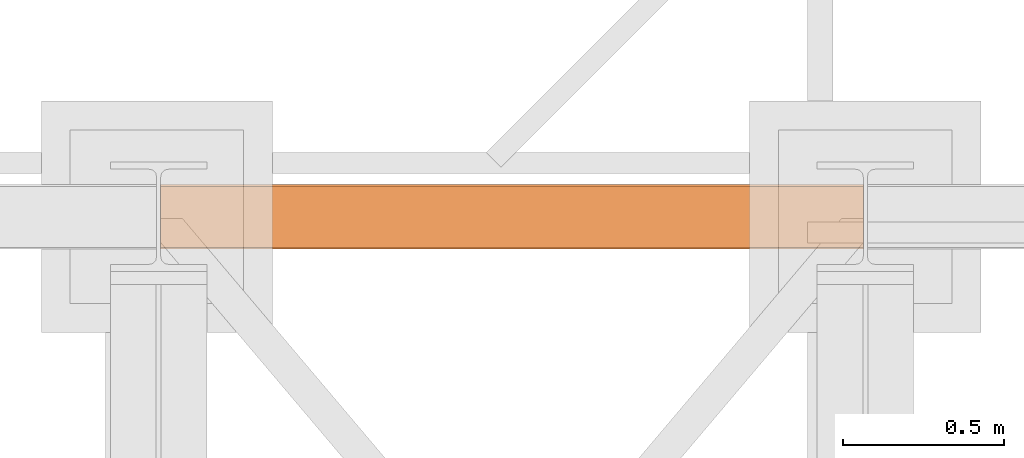
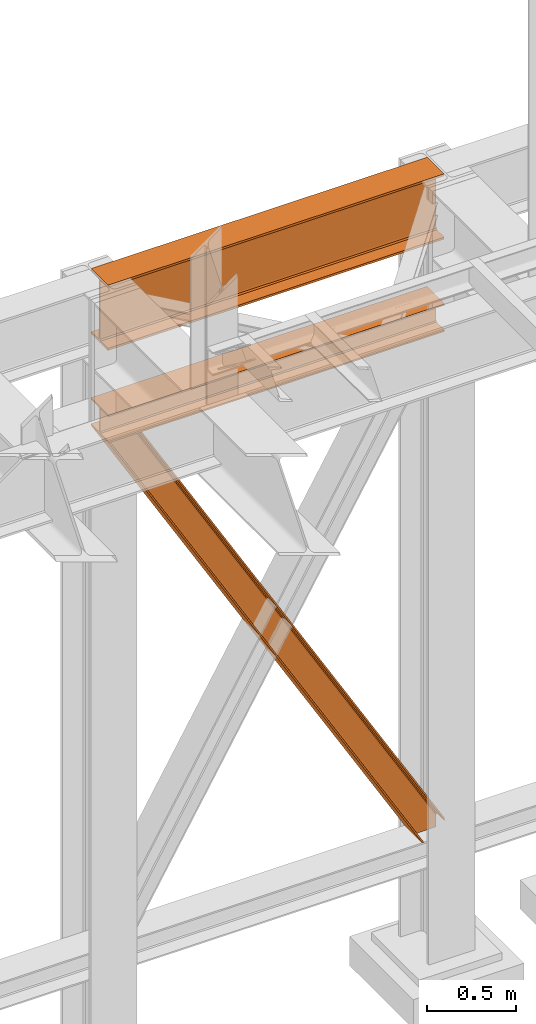
# One storey, part 191 of 208: 3 proxies.
"""IFC2X3 building model written with IfcOpenShell, lengths in millimetres."""

from ifc_helpers import new_model, entity, si_unit, converted_unit, frame, origin, origin_with_axes, place, context, subcontext, project, spatial, faceted_brep, element, save


model = new_model("IFC2X3")

# Units and contexts
model_context = context("Model", 3, precision=1e-05, world=origin())
plan_context = context("Plan", 3, precision=1e-05, world=origin())
body_context = subcontext(model_context, "Body", "Model", "MODEL_VIEW")
ifc_project = project(units=[si_unit("LENGTHUNIT", "METRE", prefix="MILLI"), converted_unit("PLANEANGLEUNIT", "DEGREE", entity("IfcPlaneAngleMeasure", 0.0174532925199433), si_unit("PLANEANGLEUNIT", "RADIAN"), dimensions=[0, 0, 0, 0, 0, 0, 0]), si_unit("AREAUNIT", "SQUARE_METRE"), si_unit("VOLUMEUNIT", "CUBIC_METRE")], contexts=[model_context, plan_context])

# Building, storey
building_placement = place(None, origin())
building = spatial("IfcBuilding", under=ifc_project, at=building_placement, CompositionType="COMPLEX")
storey_placement = place(building_placement, origin_with_axes())
storey = spatial("IfcBuildingStorey", under=building, at=storey_placement, Name="Geschoss", CompositionType="ELEMENT")

# Proxies
proxy_1_placement = place(storey_placement, frame((3299.254968580828, -12557.574399786, 4834.989987483023), z_axis=(0.0, 0.0, 1.0), x_axis=(1.0, 0.0, 0.0)))
element("IfcBuildingElementProxy", 1, at=proxy_1_placement, inside=storey, context=body_context, shape_type="Brep", body=[
    faceted_brep([(2188.009999895692, 0.00999999999839929, 450.0100178813937), (2188.009999895692, 190.0100125169738, 450.0100178813937), (2188.009999895692, 190.0100125169738, 435.4100240564349), (2188.009999895692, 120.7100073045476, 435.4100091552737), (2188.009999895692, 109.8415622657522, 433.2347078418734), (2188.009999895692, 101.8853126263603, 425.2784563398363), (2188.009999895692, 99.71000619068582, 414.4100113010409), (2188.009999895692, 99.71000619068582, 35.60999167919181), (2188.009999895692, 101.8853126263603, 24.74154664039634), (2188.009999895692, 109.8415622657522, 16.78529513835929), (2188.009999895692, 120.7100073045476, 14.60999382495902), (2188.009999895692, 190.0100125169738, 14.60999382495902), (2188.009999895692, 190.0100125169738, 0.01000000000021828), (2188.009999895692, 0.00999999999839929, 0.01000000000021828), (2188.009999895692, 0.00999999999839929, 14.60999382495902), (2188.009999895692, 69.31000521242458, 14.60999382495902), (2188.009999895692, 80.17845025122006, 16.78529513835929), (2188.009999895692, 88.13469989061196, 24.74154664039634), (2188.009999895692, 90.31000632628638, 35.60999167919181), (2188.009999895692, 90.31000632628638, 414.4100113010409), (2188.009999895692, 88.13469989061196, 425.2784563398363), (2188.009999895692, 80.17845025122006, 433.2347078418734), (2188.009999895692, 69.31000521242458, 435.4100091552737), (2188.009999895692, 0.00999999999839929, 435.4100240564349), (2188.009999895692, 190.0100125169738, 450.0100178813937), (2188.009999895692, 0.00999999999839929, 450.0100178813937), (0.01000000000021828, 0.01000000000021828, 450.0100178813937), (0.01000000000021828, 190.0100125169756, 450.0100178813937), (2188.009999895692, 190.0100125169738, 435.4100240564349), (2188.009999895692, 190.0100125169738, 450.0100178813937), (0.01000000000021828, 190.0100125169756, 450.0100178813937), (0.01000000000021828, 190.0100125169756, 435.4100240564349), (2188.009999895692, 120.7100073045476, 435.4100091552737), (2188.009999895692, 190.0100125169738, 435.4100240564349), (0.01000000000021828, 190.0100125169756, 435.4100240564349), (0.01000000000021828, 120.7100073045494, 435.4100091552737), (2188.009999895692, 109.8415622657522, 433.2347078418734), (2188.009999895692, 120.7100073045476, 435.4100091552737), (0.01000000000021828, 120.7100073045494, 435.4100091552737), (0.01000000000021828, 109.841562265754, 433.2347078418734), (2188.009999895692, 101.8853126263603, 425.2784563398363), (2188.009999895692, 109.8415622657522, 433.2347078418734), (0.01000000000021828, 109.841562265754, 433.2347078418734), (0.01000000000021828, 101.8853126263621, 425.2784563398363), (2188.009999895692, 99.71000619068582, 414.4100113010409), (2188.009999895692, 101.8853126263603, 425.2784563398363), (0.01000000000021828, 101.8853126263621, 425.2784563398363), (0.01000000000021828, 99.71000619068764, 414.4100113010409), (2188.009999895692, 99.71000619068582, 35.60999167919181), (2188.009999895692, 99.71000619068582, 414.4100113010409), (0.01000000000021828, 99.71000619068764, 414.4100113010409), (0.01000000000021828, 99.71000619068764, 35.60999167919181), (2188.009999895692, 101.8853126263603, 24.74154664039634), (2188.009999895692, 99.71000619068582, 35.60999167919181), (0.01000000000021828, 99.71000619068764, 35.60999167919181), (0.01000000000021828, 101.8853126263621, 24.74154664039634), (2188.009999895692, 109.8415622657522, 16.78529513835929), (2188.009999895692, 101.8853126263603, 24.74154664039634), (0.01000000000021828, 101.8853126263621, 24.74154664039634), (0.01000000000021828, 109.841562265754, 16.78529513835929), (2188.009999895692, 120.7100073045476, 14.60999382495902), (2188.009999895692, 109.8415622657522, 16.78529513835929), (0.01000000000021828, 109.841562265754, 16.78529513835929), (0.01000000000021828, 120.7100073045494, 14.60999382495902), (2188.009999895692, 190.0100125169738, 14.60999382495902), (2188.009999895692, 120.7100073045476, 14.60999382495902), (0.01000000000021828, 120.7100073045494, 14.60999382495902), (0.01000000000021828, 190.0100125169756, 14.60999382495902), (2188.009999895692, 190.0100125169738, 0.01000000000021828), (2188.009999895692, 190.0100125169738, 14.60999382495902), (0.01000000000021828, 190.0100125169756, 14.60999382495902), (0.01000000000021828, 190.0100125169756, 0.01000000000021828), (2188.009999895692, 0.00999999999839929, 0.01000000000021828), (2188.009999895692, 190.0100125169738, 0.01000000000021828), (0.01000000000021828, 190.0100125169756, 0.01000000000021828), (0.01000000000021828, 0.01000000000021828, 0.01000000000021828), (2188.009999895692, 0.00999999999839929, 14.60999382495902), (2188.009999895692, 0.00999999999839929, 0.01000000000021828), (0.01000000000021828, 0.01000000000021828, 0.01000000000021828), (0.01000000000021828, 0.01000000000021828, 14.60999382495902), (2188.009999895692, 69.31000521242458, 14.60999382495902), (2188.009999895692, 0.00999999999839929, 14.60999382495902), (0.01000000000021828, 0.01000000000021828, 14.60999382495902), (0.01000000000021828, 69.3100052124264, 14.60999382495902), (2188.009999895692, 80.17845025122006, 16.78529513835929), (2188.009999895692, 69.31000521242458, 14.60999382495902), (0.01000000000021828, 69.3100052124264, 14.60999382495902), (0.01000000000021828, 80.17845025122188, 16.78529513835929), (2188.009999895692, 88.13469989061196, 24.74154664039634), (2188.009999895692, 80.17845025122006, 16.78529513835929), (0.01000000000021828, 80.17845025122188, 16.78529513835929), (0.01000000000021828, 88.13469989061377, 24.74154664039634), (2188.009999895692, 90.31000632628638, 35.60999167919181), (2188.009999895692, 88.13469989061196, 24.74154664039634), (0.01000000000021828, 88.13469989061377, 24.74154664039634), (0.01000000000021828, 90.3100063262882, 35.60999167919181), (2188.009999895692, 90.31000632628638, 414.4100113010409), (2188.009999895692, 90.31000632628638, 35.60999167919181), (0.01000000000021828, 90.3100063262882, 35.60999167919181), (0.01000000000021828, 90.3100063262882, 414.4100113010409), (2188.009999895692, 88.13469989061196, 425.2784563398363), (2188.009999895692, 90.31000632628638, 414.4100113010409), (0.01000000000021828, 90.3100063262882, 414.4100113010409), (0.01000000000021828, 88.13469989061377, 425.2784563398363), (2188.009999895692, 80.17845025122006, 433.2347078418734), (2188.009999895692, 88.13469989061196, 425.2784563398363), (0.01000000000021828, 88.13469989061377, 425.2784563398363), (0.01000000000021828, 80.17845025122188, 433.2347078418734), (2188.009999895692, 69.31000521242458, 435.4100091552737), (2188.009999895692, 80.17845025122006, 433.2347078418734), (0.01000000000021828, 80.17845025122188, 433.2347078418734), (0.01000000000021828, 69.3100052124264, 435.4100091552737), (2188.009999895692, 0.00999999999839929, 435.4100240564349), (2188.009999895692, 69.31000521242458, 435.4100091552737), (0.01000000000021828, 69.3100052124264, 435.4100091552737), (0.01000000000021828, 0.01000000000021828, 435.4100240564349), (2188.009999895692, 0.00999999999839929, 450.0100178813937), (2188.009999895692, 0.00999999999839929, 435.4100240564349), (0.01000000000021828, 0.01000000000021828, 435.4100240564349), (0.01000000000021828, 0.01000000000021828, 450.0100178813937), (0.01000000000021828, 0.01000000000021828, 450.0100178813937), (0.01000000000021828, 0.01000000000021828, 435.4100240564349), (0.01000000000021828, 69.3100052124264, 435.4100091552737), (0.01000000000021828, 80.17845025122188, 433.2347078418734), (0.01000000000021828, 88.13469989061377, 425.2784563398363), (0.01000000000021828, 90.3100063262882, 414.4100113010409), (0.01000000000021828, 90.3100063262882, 35.60999167919181), (0.01000000000021828, 88.13469989061377, 24.74154664039634), (0.01000000000021828, 80.17845025122188, 16.78529513835929), (0.01000000000021828, 69.3100052124264, 14.60999382495902), (0.01000000000021828, 0.01000000000021828, 14.60999382495902), (0.01000000000021828, 0.01000000000021828, 0.01000000000021828), (0.01000000000021828, 190.0100125169756, 0.01000000000021828), (0.01000000000021828, 190.0100125169756, 14.60999382495902), (0.01000000000021828, 120.7100073045494, 14.60999382495902), (0.01000000000021828, 109.841562265754, 16.78529513835929), (0.01000000000021828, 101.8853126263621, 24.74154664039634), (0.01000000000021828, 99.71000619068764, 35.60999167919181), (0.01000000000021828, 99.71000619068764, 414.4100113010409), (0.01000000000021828, 101.8853126263621, 425.2784563398363), (0.01000000000021828, 109.841562265754, 433.2347078418734), (0.01000000000021828, 120.7100073045494, 435.4100091552737), (0.01000000000021828, 190.0100125169756, 435.4100240564349), (0.01000000000021828, 190.0100125169756, 450.0100178813937)], [[[0, 1, 2, 3, 4, 5, 6, 7, 8, 9, 10, 11, 12, 13, 14, 15, 16, 17, 18, 19, 20, 21, 22, 23]], [[24, 25, 26, 27]], [[28, 29, 30, 31]], [[32, 33, 34, 35]], [[36, 37, 38, 39]], [[40, 41, 42, 43]], [[44, 45, 46, 47]], [[48, 49, 50, 51]], [[52, 53, 54, 55]], [[56, 57, 58, 59]], [[60, 61, 62, 63]], [[64, 65, 66, 67]], [[68, 69, 70, 71]], [[72, 73, 74, 75]], [[76, 77, 78, 79]], [[80, 81, 82, 83]], [[84, 85, 86, 87]], [[88, 89, 90, 91]], [[92, 93, 94, 95]], [[96, 97, 98, 99]], [[100, 101, 102, 103]], [[104, 105, 106, 107]], [[108, 109, 110, 111]], [[112, 113, 114, 115]], [[116, 117, 118, 119]], [[120, 121, 122, 123, 124, 125, 126, 127, 128, 129, 130, 131, 132, 133, 134, 135, 136, 137, 138, 139, 140, 141, 142, 143]]], orient=[[False], [False], [False], [False], [False], [False], [False], [False], [False], [False], [False], [False], [False], [False], [False], [False], [False], [False], [False], [False], [False], [False], [False], [False], [False], [False]]),
])
proxy_2_placement = place(storey_placement, frame((3299.254968580823, -12562.57439501764, 4202.989992847441), z_axis=(0.0, 0.0, 1.0), x_axis=(1.0, 0.0, 0.0)))
element("IfcBuildingElementProxy", 2, at=proxy_2_placement, inside=storey, context=body_context, shape_type="Brep", body=[
    faceted_brep([(2188.00999989569, 0.01000000000021828, 190.0100125169756), (2188.00999989569, 200.0100029802325, 190.0100125169756), (2188.00999989569, 200.0100029802325, 180.0100146031382), (2188.00999989569, 121.2600035762789, 180.0100071525576), (2188.00999989569, 111.9441915473344, 178.1454621052744), (2188.00999989569, 105.1245498640838, 171.3258190250399), (2188.00999989569, 103.2600015571716, 162.010007927418), (2188.00999989569, 103.2600015571716, 28.00999713897727), (2188.00999989569, 105.1245498640838, 18.69418604135535), (2188.00999989569, 111.9441915473344, 11.87454296112082), (2188.00999989569, 121.2600035762789, 10.00999791383765), (2188.00999989569, 200.0100029802325, 10.00999791383765), (2188.00999989569, 200.0100029802325, 0.01000000000021828), (2188.00999989569, 0.01000000000021828, 0.01000000000021828), (2188.00999989569, 0.01000000000021828, 10.00999791383765), (2188.00999989569, 78.75999940395377, 10.00999791383765), (2188.00999989569, 88.07581143289826, 11.87454296112082), (2188.00999989569, 94.89545311614893, 18.69418604135535), (2188.00999989569, 96.76000142306111, 28.00999713897727), (2188.00999989569, 96.76000142306111, 162.010007927418), (2188.00999989569, 94.89545311614893, 171.3258190250399), (2188.00999989569, 88.07581143289826, 178.1454621052744), (2188.00999989569, 78.75999940395377, 180.0100071525576), (2188.00999989569, 0.01000000000021828, 180.0100146031382), (2188.00999989569, 200.0100029802325, 190.0100125169756), (2188.00999989569, 0.01000000000021828, 190.0100125169756), (0.01000000000021828, 0.01000000000021828, 190.0100125169756), (0.01000000000021828, 200.0100029802325, 190.0100125169756), (2188.00999989569, 200.0100029802325, 180.0100146031382), (2188.00999989569, 200.0100029802325, 190.0100125169756), (0.01000000000021828, 200.0100029802325, 190.0100125169756), (0.01000000000021828, 200.0100029802325, 180.0100146031382), (2188.00999989569, 121.2600035762789, 180.0100071525576), (2188.00999989569, 200.0100029802325, 180.0100146031382), (0.01000000000021828, 200.0100029802325, 180.0100146031382), (0.01000000000021828, 121.2600035762789, 180.0100071525576), (2188.00999989569, 111.9441915473344, 178.1454621052744), (2188.00999989569, 121.2600035762789, 180.0100071525576), (0.01000000000021828, 121.2600035762789, 180.0100071525576), (0.01000000000021828, 111.9441915473344, 178.1454621052744), (2188.00999989569, 105.1245498640838, 171.3258190250399), (2188.00999989569, 111.9441915473344, 178.1454621052744), (0.01000000000021828, 111.9441915473344, 178.1454621052744), (0.01000000000021828, 105.1245498640838, 171.3258190250399), (2188.00999989569, 103.2600015571716, 162.010007927418), (2188.00999989569, 105.1245498640838, 171.3258190250399), (0.01000000000021828, 105.1245498640838, 171.3258190250399), (0.01000000000021828, 103.2600015571716, 162.010007927418), (2188.00999989569, 103.2600015571716, 28.00999713897727), (2188.00999989569, 103.2600015571716, 162.010007927418), (0.01000000000021828, 103.2600015571716, 162.010007927418), (0.01000000000021828, 103.2600015571716, 28.00999713897727), (2188.00999989569, 105.1245498640838, 18.69418604135535), (2188.00999989569, 103.2600015571716, 28.00999713897727), (0.01000000000021828, 103.2600015571716, 28.00999713897727), (0.01000000000021828, 105.1245498640838, 18.69418604135535), (2188.00999989569, 111.9441915473344, 11.87454296112082), (2188.00999989569, 105.1245498640838, 18.69418604135535), (0.01000000000021828, 105.1245498640838, 18.69418604135535), (0.01000000000021828, 111.9441915473344, 11.87454296112082), (2188.00999989569, 121.2600035762789, 10.00999791383765), (2188.00999989569, 111.9441915473344, 11.87454296112082), (0.01000000000021828, 111.9441915473344, 11.87454296112082), (0.01000000000021828, 121.2600035762789, 10.00999791383765), (2188.00999989569, 200.0100029802325, 10.00999791383765), (2188.00999989569, 121.2600035762789, 10.00999791383765), (0.01000000000021828, 121.2600035762789, 10.00999791383765), (0.01000000000021828, 200.0100029802325, 10.00999791383765), (2188.00999989569, 200.0100029802325, 0.01000000000021828), (2188.00999989569, 200.0100029802325, 10.00999791383765), (0.01000000000021828, 200.0100029802325, 10.00999791383765), (0.01000000000021828, 200.0100029802325, 0.01000000000021828), (2188.00999989569, 0.01000000000021828, 0.01000000000021828), (2188.00999989569, 200.0100029802325, 0.01000000000021828), (0.01000000000021828, 200.0100029802325, 0.01000000000021828), (0.01000000000021828, 0.01000000000021828, 0.01000000000021828), (2188.00999989569, 0.01000000000021828, 10.00999791383765), (2188.00999989569, 0.01000000000021828, 0.01000000000021828), (0.01000000000021828, 0.01000000000021828, 0.01000000000021828), (0.01000000000021828, 0.01000000000021828, 10.00999791383765), (2188.00999989569, 78.75999940395377, 10.00999791383765), (2188.00999989569, 0.01000000000021828, 10.00999791383765), (0.01000000000021828, 0.01000000000021828, 10.00999791383765), (0.01000000000021828, 78.75999940395377, 10.00999791383765), (2188.00999989569, 88.07581143289826, 11.87454296112082), (2188.00999989569, 78.75999940395377, 10.00999791383765), (0.01000000000021828, 78.75999940395377, 10.00999791383765), (0.01000000000021828, 88.07581143289826, 11.87454296112082), (2188.00999989569, 94.89545311614893, 18.69418604135535), (2188.00999989569, 88.07581143289826, 11.87454296112082), (0.01000000000021828, 88.07581143289826, 11.87454296112082), (0.01000000000021828, 94.89545311614893, 18.69418604135535), (2188.00999989569, 96.76000142306111, 28.00999713897727), (2188.00999989569, 94.89545311614893, 18.69418604135535), (0.01000000000021828, 94.89545311614893, 18.69418604135535), (0.01000000000021828, 96.76000142306111, 28.00999713897727), (2188.00999989569, 96.76000142306111, 162.010007927418), (2188.00999989569, 96.76000142306111, 28.00999713897727), (0.01000000000021828, 96.76000142306111, 28.00999713897727), (0.01000000000021828, 96.76000142306111, 162.010007927418), (2188.00999989569, 94.89545311614893, 171.3258190250399), (2188.00999989569, 96.76000142306111, 162.010007927418), (0.01000000000021828, 96.76000142306111, 162.010007927418), (0.01000000000021828, 94.89545311614893, 171.3258190250399), (2188.00999989569, 88.07581143289826, 178.1454621052744), (2188.00999989569, 94.89545311614893, 171.3258190250399), (0.01000000000021828, 94.89545311614893, 171.3258190250399), (0.01000000000021828, 88.07581143289826, 178.1454621052744), (2188.00999989569, 78.75999940395377, 180.0100071525576), (2188.00999989569, 88.07581143289826, 178.1454621052744), (0.01000000000021828, 88.07581143289826, 178.1454621052744), (0.01000000000021828, 78.75999940395377, 180.0100071525576), (2188.00999989569, 0.01000000000021828, 180.0100146031382), (2188.00999989569, 78.75999940395377, 180.0100071525576), (0.01000000000021828, 78.75999940395377, 180.0100071525576), (0.01000000000021828, 0.01000000000021828, 180.0100146031382), (2188.00999989569, 0.01000000000021828, 190.0100125169756), (2188.00999989569, 0.01000000000021828, 180.0100146031382), (0.01000000000021828, 0.01000000000021828, 180.0100146031382), (0.01000000000021828, 0.01000000000021828, 190.0100125169756), (0.01000000000021828, 0.01000000000021828, 190.0100125169756), (0.01000000000021828, 0.01000000000021828, 180.0100146031382), (0.01000000000021828, 78.75999940395377, 180.0100071525576), (0.01000000000021828, 88.07581143289826, 178.1454621052744), (0.01000000000021828, 94.89545311614893, 171.3258190250399), (0.01000000000021828, 96.76000142306111, 162.010007927418), (0.01000000000021828, 96.76000142306111, 28.00999713897727), (0.01000000000021828, 94.89545311614893, 18.69418604135535), (0.01000000000021828, 88.07581143289826, 11.87454296112082), (0.01000000000021828, 78.75999940395377, 10.00999791383765), (0.01000000000021828, 0.01000000000021828, 10.00999791383765), (0.01000000000021828, 0.01000000000021828, 0.01000000000021828), (0.01000000000021828, 200.0100029802325, 0.01000000000021828), (0.01000000000021828, 200.0100029802325, 10.00999791383765), (0.01000000000021828, 121.2600035762789, 10.00999791383765), (0.01000000000021828, 111.9441915473344, 11.87454296112082), (0.01000000000021828, 105.1245498640838, 18.69418604135535), (0.01000000000021828, 103.2600015571716, 28.00999713897727), (0.01000000000021828, 103.2600015571716, 162.010007927418), (0.01000000000021828, 105.1245498640838, 171.3258190250399), (0.01000000000021828, 111.9441915473344, 178.1454621052744), (0.01000000000021828, 121.2600035762789, 180.0100071525576), (0.01000000000021828, 200.0100029802325, 180.0100146031382), (0.01000000000021828, 200.0100029802325, 190.0100125169756)], [[[0, 1, 2, 3, 4, 5, 6, 7, 8, 9, 10, 11, 12, 13, 14, 15, 16, 17, 18, 19, 20, 21, 22, 23]], [[24, 25, 26, 27]], [[28, 29, 30, 31]], [[32, 33, 34, 35]], [[36, 37, 38, 39]], [[40, 41, 42, 43]], [[44, 45, 46, 47]], [[48, 49, 50, 51]], [[52, 53, 54, 55]], [[56, 57, 58, 59]], [[60, 61, 62, 63]], [[64, 65, 66, 67]], [[68, 69, 70, 71]], [[72, 73, 74, 75]], [[76, 77, 78, 79]], [[80, 81, 82, 83]], [[84, 85, 86, 87]], [[88, 89, 90, 91]], [[92, 93, 94, 95]], [[96, 97, 98, 99]], [[100, 101, 102, 103]], [[104, 105, 106, 107]], [[108, 109, 110, 111]], [[112, 113, 114, 115]], [[116, 117, 118, 119]], [[120, 121, 122, 123, 124, 125, 126, 127, 128, 129, 130, 131, 132, 133, 134, 135, 136, 137, 138, 139, 140, 141, 142, 143]]], orient=[[False], [False], [False], [False], [False], [False], [False], [False], [False], [False], [False], [False], [False], [False], [False], [False], [False], [False], [False], [False], [False], [False], [False], [False], [False], [False]]),
])
proxy_3_placement = place(storey_placement, frame((3299.832450539901, -12562.57439501764, 734.9900149335328), z_axis=(0.0, 0.0, 1.0), x_axis=(1.0, 0.0, 0.0)))
element("IfcBuildingElementProxy", 3, at=proxy_3_placement, inside=storey, context=body_context, shape_type="Brep", body=[
    faceted_brep([(2187.432517936612, 0.01000000000021828, 120.8497915510924), (216.8471928951321, 0.01000000000021828, 3468.009977913908), (216.8471928951321, 200.0100029802325, 3468.009977913908), (2187.432517936612, 200.0100029802325, 120.8497915510924), (2187.432517936612, 200.0100029802325, 120.8497915510924), (216.8471928951321, 200.0100029802325, 3468.009977913908), (205.4347121912169, 200.0100029802325, 3468.009977913908), (2187.432517936612, 200.0100029802325, 101.4682129393398), (2187.432517936612, 200.0100029802325, 101.4682129393398), (205.4347121912169, 200.0100029802325, 3468.009977913908), (205.4347036882541, 121.2600035762789, 3468.009977913908), (2187.432517936951, 121.2600035762789, 101.4681984983711), (2187.432517936951, 121.2600035762789, 101.4681984983711), (205.4347036882541, 121.2600035762789, 3468.009977913908), (203.306794806967, 111.9441915473344, 3468.009977913909), (2187.432602958225, 111.9441915473344, 97.85427409430258), (2187.432602958225, 111.9441915473344, 97.85427409430258), (203.306794806967, 111.9441915473344, 3468.009977913909), (195.5238886772499, 105.1245498640838, 3468.009977913908), (2187.432517936612, 105.1245498640838, 84.63689245399041), (2187.432517936612, 105.1245498640838, 84.63689245399041), (195.5238886772499, 105.1245498640838, 3468.009977913908), (184.892235020021, 103.2600015571716, 3468.009977913908), (2187.432517936612, 103.2600015571716, 66.58142866151923), (2187.432517936612, 103.2600015571716, 0.009999999999990905), (2187.432517936612, 103.2600015571716, 66.58142866151923), (184.892235020021, 103.2600015571716, 3468.009977913908), (31.96494937214857, 103.2600015571716, 3468.009977913908), (2073.723887154785, 103.2600015571716, 0.01000000000021828), (2073.723887154785, 103.2600015571716, 0.01000000000021828), (31.96494937214857, 103.2600015571716, 3468.009977913908), (21.33329571491913, 105.1245498640838, 3468.009977913908), (2063.093996904378, 105.1245498640838, 0.01000000000010459), (2063.093996904378, 105.1245498640838, 0.01000000000010459), (21.33329571491913, 105.1245498640838, 3468.009977913908), (13.55038958520254, 111.9441915473344, 3468.009977913908), (2055.312379673187, 111.9441915473344, 0.009999999999763531), (2055.312379673187, 111.9441915473344, 0.009999999999763531), (13.55038958520254, 111.9441915473344, 3468.009977913908), (11.42248070391588, 121.2600035762789, 3468.009977913907), (2053.184822892688, 121.2600035762789, 0.009999999999763531), (2053.184822892688, 121.2600035762789, 0.009999999999763531), (11.42248070391588, 121.2600035762789, 3468.009977913907), (11.42248070391634, 200.0100029802325, 3468.009977913907), (2053.184822892688, 200.0100029802325, 0.009999999999763531), (2053.184822892688, 200.0100029802325, 0.009999999999763531), (11.42248070391634, 200.0100029802325, 3468.009977913907), (0.01000000000021828, 200.0100029802325, 3468.009977913908), (2041.774228435658, 200.0100029802325, 0.009999999999990905), (2041.774228435658, 200.0100029802325, 0.009999999999990905), (0.01000000000021828, 200.0100029802325, 3468.009977913908), (0.01000000000021828, 0.01000000000021828, 3468.009977913908), (2041.774228435658, 0.01000000000021828, 0.009999999999990905), (2041.774228435658, 0.01000000000021828, 0.009999999999990905), (0.01000000000021828, 0.01000000000021828, 3468.009977913908), (11.42248070391679, 0.01000000000021828, 3468.009977913908), (2053.184822892688, 0.01000000000021828, 0.009999999999877218), (2053.184822892688, 0.01000000000021828, 0.009999999999877218), (11.42248070391679, 0.01000000000021828, 3468.009977913908), (11.42248070391634, 78.75999940395377, 3468.009977913907), (2053.184822892688, 78.75999940395377, 0.009999999999763531), (2053.184822892688, 78.75999940395377, 0.009999999999763531), (11.42248070391634, 78.75999940395377, 3468.009977913907), (13.55038958520254, 88.07581143290008, 3468.009977913908), (2055.312379673187, 88.07581143289826, 0.009999999999763531), (2055.312379673187, 88.07581143289826, 0.009999999999763531), (13.55038958520254, 88.07581143290008, 3468.009977913908), (21.33329571491913, 94.89545311614893, 3468.009977913908), (2063.093996904378, 94.89545311614893, 0.009999999999763531), (2063.093996904378, 94.89545311614893, 0.009999999999763531), (21.33329571491913, 94.89545311614893, 3468.009977913908), (31.96494937214857, 96.76000142306111, 3468.009977913908), (2073.723887154785, 96.76000142306111, 0.01000000000021828), (2073.723887154785, 96.76000142306111, 0.01000000000021828), (31.96494937214857, 96.76000142306111, 3468.009977913908), (184.892235020021, 96.76000142306111, 3468.009977913908), (2187.432517936612, 96.76000142306111, 66.58142866151888), (2187.432517936612, 96.76000142306111, 0.009999999999990905), (2187.432517936612, 96.76000142306111, 66.58142866151888), (184.892235020021, 96.76000142306111, 3468.009977913908), (195.5238886772499, 94.89545311614893, 3468.009977913908), (2187.432517936612, 94.89545311615075, 84.63689245399041), (2187.432517936612, 94.89545311615075, 84.63689245399041), (195.5238886772499, 94.89545311614893, 3468.009977913908), (203.306794806967, 88.07581143289826, 3468.009977913909), (2187.432517936612, 88.07581143289826, 97.85441850857092), (2187.432517936612, 88.07581143289826, 97.85441850857092), (203.306794806967, 88.07581143289826, 3468.009977913909), (205.4347036882546, 78.75999940395377, 3468.009977913908), (2187.432433072335, 78.75999940395377, 101.4683426459951), (2187.432433072335, 78.75999940395377, 101.4683426459951), (205.4347036882546, 78.75999940395377, 3468.009977913908), (205.4347121912169, 0.01000000000021828, 3468.009977913908), (2187.432517936272, 0.01000000000021828, 101.4682129399164), (2187.432517936272, 0.01000000000021828, 101.4682129399164), (205.4347121912169, 0.01000000000021828, 3468.009977913908), (216.8471928951321, 0.01000000000021828, 3468.009977913908), (2187.432517936612, 0.01000000000021828, 120.8497915510924), (216.8471928951321, 0.01000000000021828, 3468.009977913908), (205.4347121912169, 0.01000000000021828, 3468.009977913908), (205.4347036882546, 78.75999940395377, 3468.009977913908), (203.306794806967, 88.07581143289826, 3468.009977913909), (195.5238886772499, 94.89545311614893, 3468.009977913908), (184.892235020021, 96.76000142306111, 3468.009977913908), (31.96494937214857, 96.76000142306111, 3468.009977913908), (21.33329571491913, 94.89545311614893, 3468.009977913908), (13.55038958520254, 88.07581143290008, 3468.009977913908), (11.42248070391634, 78.75999940395377, 3468.009977913907), (11.42248070391679, 0.01000000000021828, 3468.009977913908), (0.01000000000021828, 0.01000000000021828, 3468.009977913908), (0.01000000000021828, 200.0100029802325, 3468.009977913908), (11.42248070391634, 200.0100029802325, 3468.009977913907), (11.42248070391588, 121.2600035762789, 3468.009977913907), (13.55038958520254, 111.9441915473344, 3468.009977913908), (21.33329571491913, 105.1245498640838, 3468.009977913908), (31.96494937214857, 103.2600015571716, 3468.009977913908), (184.892235020021, 103.2600015571716, 3468.009977913908), (195.5238886772499, 105.1245498640838, 3468.009977913908), (203.306794806967, 111.9441915473344, 3468.009977913909), (205.4347036882541, 121.2600035762789, 3468.009977913908), (205.4347121912169, 200.0100029802325, 3468.009977913908), (216.8471928951321, 200.0100029802325, 3468.009977913908), (2187.432517936612, 96.76000142306111, 0.009999999999990905), (2187.432517936612, 96.76000142306111, 66.58142866151888), (2187.432517936612, 94.89545311615075, 84.63689245399041), (2187.432517936612, 88.07581143289826, 97.85441850857092), (2187.432433072335, 78.75999940395377, 101.4683426459951), (2187.432517936272, 0.01000000000021828, 101.4682129399164), (2187.432517936612, 0.01000000000021828, 120.8497915510924), (2187.432517936612, 200.0100029802325, 120.8497915510924), (2187.432517936612, 200.0100029802325, 101.4682129393398), (2187.432517936951, 121.2600035762789, 101.4681984983711), (2187.432602958225, 111.9441915473344, 97.85427409430258), (2187.432517936612, 105.1245498640838, 84.63689245399041), (2187.432517936612, 103.2600015571716, 66.58142866151923), (2187.432517936612, 103.2600015571716, 0.009999999999990905), (2073.723887154785, 103.2600015571716, 0.01000000000021828), (2063.093996904378, 105.1245498640838, 0.01000000000010459), (2055.312379673187, 111.9441915473344, 0.009999999999763531), (2053.184822892688, 121.2600035762789, 0.009999999999763531), (2053.184822892688, 200.0100029802325, 0.009999999999763531), (2041.774228435658, 200.0100029802325, 0.009999999999990905), (2041.774228435658, 0.01000000000021828, 0.009999999999990905), (2053.184822892688, 0.01000000000021828, 0.009999999999877218), (2053.184822892688, 78.75999940395377, 0.009999999999763531), (2055.312379673187, 88.07581143289826, 0.009999999999763531), (2063.093996904378, 94.89545311614893, 0.009999999999763531), (2073.723887154785, 96.76000142306111, 0.01000000000021828), (2187.432517936612, 96.76000142306111, 0.009999999999990905), (2187.432517936612, 103.2600015571716, 0.009999999999990905)], [[[0, 1, 2, 3]], [[4, 5, 6, 7]], [[8, 9, 10, 11]], [[12, 13, 14, 15]], [[16, 17, 18, 19]], [[20, 21, 22, 23]], [[24, 25, 26, 27, 28]], [[29, 30, 31, 32]], [[33, 34, 35, 36]], [[37, 38, 39, 40]], [[41, 42, 43, 44]], [[45, 46, 47, 48]], [[49, 50, 51, 52]], [[53, 54, 55, 56]], [[57, 58, 59, 60]], [[61, 62, 63, 64]], [[65, 66, 67, 68]], [[69, 70, 71, 72]], [[73, 74, 75, 76, 77]], [[78, 79, 80, 81]], [[82, 83, 84, 85]], [[86, 87, 88, 89]], [[90, 91, 92, 93]], [[94, 95, 96, 97]], [[98, 99, 100, 101, 102, 103, 104, 105, 106, 107, 108, 109, 110, 111, 112, 113, 114, 115, 116, 117, 118, 119, 120, 121]], [[122, 123, 124, 125, 126, 127, 128, 129, 130, 131, 132, 133, 134, 135]], [[136, 137, 138, 139, 140, 141, 142, 143, 144, 145, 146, 147, 148, 149]]], orient=[[False], [False], [False], [False], [False], [False], [False], [False], [False], [False], [False], [False], [False], [False], [False], [False], [False], [False], [False], [False], [False], [False], [False], [False], [False], [False], [False]]),
])

save(model, "model.ifc")
